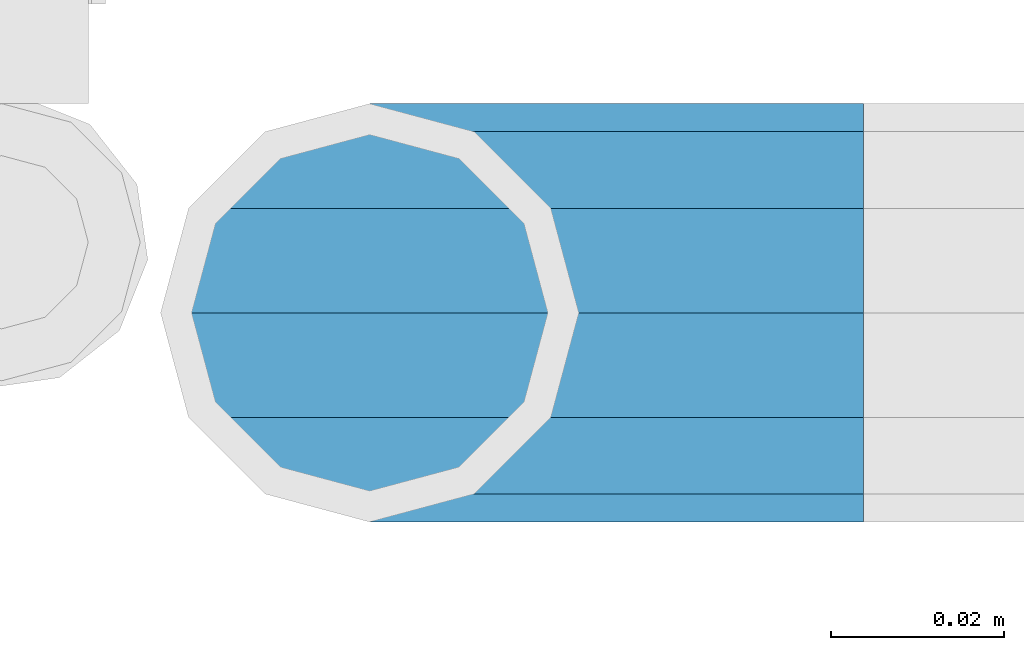
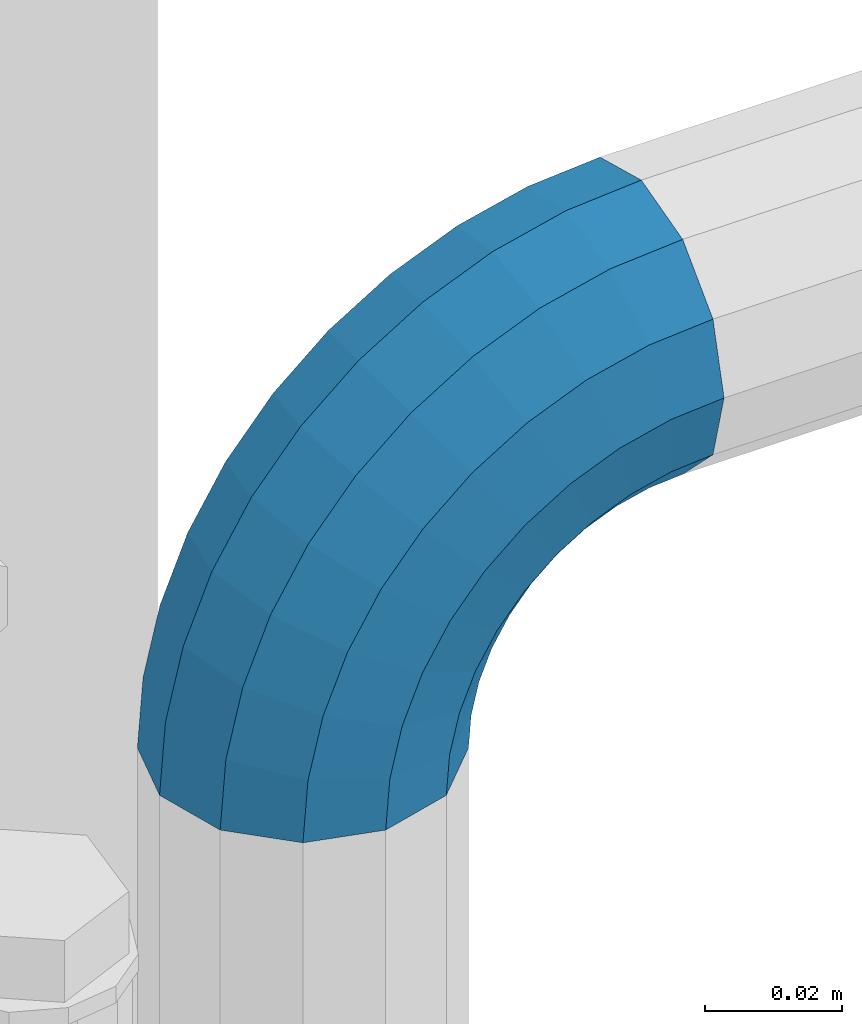
# One storey, part 146 of 208: 1 member.
"""IFC2X3 building model written with IfcOpenShell, lengths in millimetres."""

import ifcopenshell
import ifcopenshell.guid

model = None  # the IFC model being written
_history = None  # IfcOwnerHistory: only IFC2X3 demands one
_inside = {}  # id of a spatial element -> (the spatial element, [elements in it])
_under = {}  # id of a project, library or spatial element -> (it, [spatial elements below it])
_declared = {}  # id of a project -> (the project, [libraries it declares])
_typed = {}  # id of a type object -> (the type object, [elements of that type])
_made_of = {}  # id of a material, layer set ... -> (it, [elements and type objects made of it])


def new_model(schema):
    """Start an empty IFC model of exactly this schema.

    Asked for "IFC4X3", IfcOpenShell would pick the latest addendum, in which some entities
    have other attributes; the version numbers below select the first issue.
    IFC2X3 requires an IfcOwnerHistory on every rooted entity: one is made here for all.
    """
    global model, _history
    if schema == "IFC4X3":
        model = ifcopenshell.file(schema_version=(4, 3, 0, 0))
    else:
        model = ifcopenshell.file(schema=schema)
    _inside.clear()
    _under.clear()
    _declared.clear()
    _typed.clear()
    _made_of.clear()
    _history = None
    if model.schema == "IFC2X3":
        org = make("IfcOrganization", Name="unknown")
        user = make(
            "IfcPersonAndOrganization",
            ThePerson=make("IfcPerson", FamilyName="unknown"),
            TheOrganization=org,
        )
        app = make(
            "IfcApplication",
            ApplicationDeveloper=org,
            Version="unknown",
            ApplicationFullName="unknown",
            ApplicationIdentifier="unknown",
        )
        _history = make(
            "IfcOwnerHistory",
            OwningUser=user,
            OwningApplication=app,
            ChangeAction="ADDED",
            CreationDate=0,
        )
    return model


def make(cls, **values):
    """One entity of the class cls with the attributes given. An attribute that is None is left unset."""
    return model.create_entity(
        cls, **{name: value for name, value in values.items() if value is not None}
    )


def rooted(cls, **values):
    """An entity with a GlobalId (a new one), such as an element, a storey or a relation."""
    return make(cls, GlobalId=ifcopenshell.guid.new(), OwnerHistory=_history, **values)


def si_unit(unit_type, name, prefix=None):
    """IfcSIUnit, for example si_unit("LENGTHUNIT", "METRE", prefix="MILLI")."""
    return make("IfcSIUnit", UnitType=unit_type, Prefix=prefix, Name=name)


def assignment(units):
    """IfcUnitAssignment: the units of a project."""
    return None if units is None else make("IfcUnitAssignment", Units=units)


def point(xyz):
    """IfcCartesianPoint."""
    return None if xyz is None else make("IfcCartesianPoint", Coordinates=xyz)


def direction(xyz):
    """IfcDirection."""
    return None if xyz is None else make("IfcDirection", DirectionRatios=xyz)


def frame(location, z_axis=None, x_axis=None):
    """IfcAxis2Placement3D, a coordinate frame: its origin and axes. An axis left out is left unset."""
    return make(
        "IfcAxis2Placement3D",
        Location=point(location),
        Axis=direction(z_axis),
        RefDirection=direction(x_axis),
    )


def origin_with_axes():
    """The frame at (0, 0, 0) with the z axis (0, 0, 1) and the x axis (1, 0, 0) written out."""
    return frame((0.0, 0.0, 0.0), z_axis=(0.0, 0.0, 1.0), x_axis=(1.0, 0.0, 0.0))


def place(relative_to, where):
    """IfcLocalPlacement: puts the frame where relative to a parent placement (None: the world)."""
    return make(
        "IfcLocalPlacement", PlacementRelTo=relative_to, RelativePlacement=where
    )


def context(
    kind, dimensions, precision=None, world=None, true_north=None, identifier=None
):
    """IfcGeometricRepresentationContext, for example the 3D "Model" context."""
    return make(
        "IfcGeometricRepresentationContext",
        ContextIdentifier=identifier,
        ContextType=kind,
        CoordinateSpaceDimension=dimensions,
        Precision=precision,
        WorldCoordinateSystem=world,
        TrueNorth=true_north,
    )


def subcontext(parent, identifier, kind, view, scale=None):
    """IfcGeometricRepresentationSubContext, for example "Body" below "Model"."""
    return make(
        "IfcGeometricRepresentationSubContext",
        ContextIdentifier=identifier,
        ContextType=kind,
        ParentContext=parent,
        TargetScale=scale,
        TargetView=view,
    )


def project(units=None, contexts=None):
    """IfcProject with its units and contexts."""
    return rooted(
        "IfcProject",
        Name="project",
        RepresentationContexts=contexts,
        UnitsInContext=assignment(units),
    )


def spatial(cls, under=None, at=None, **own):
    """A site, building, storey or space (cls), placed at a placement, below another one or the project."""
    s = rooted(cls, ObjectPlacement=at, **own)
    if under is not None:
        _under.setdefault(under.id(), (under, []))[1].append(s)
    return s


def faces_of(points, faces, orient=None, outer=None):
    """IfcFace entities. A face is a list of loops; a loop is a list of indices into points, from 0.

    orient and outer hold one flag for each loop. By default every Orientation is true, the
    first loop of a face is its IfcFaceOuterBound and the others are IfcFaceBound.
    """
    made = []
    for i, loops in enumerate(faces):
        bounds = []
        for j, loop in enumerate(loops):
            is_outer = j == 0 if outer is None else outer[i][j]
            bounds.append(
                make(
                    "IfcFaceOuterBound" if is_outer else "IfcFaceBound",
                    Bound=make("IfcPolyLoop", Polygon=[points[k] for k in loop]),
                    Orientation=True if orient is None else orient[i][j],
                )
            )
        made.append(make("IfcFace", Bounds=bounds))
    return made


def faceted_brep(points, faces, orient=None, outer=None, voids=None):
    """IfcFacetedBrep: a solid bounded by flat faces; with voids (closed shells), ...WithVoids."""
    shared = [point(p) for p in points]
    hull = make("IfcClosedShell", CfsFaces=faces_of(shared, faces, orient, outer))
    if voids is None:
        return make("IfcFacetedBrep", Outer=hull)
    return make(
        "IfcFacetedBrepWithVoids",
        Outer=hull,
        Voids=[
            make(cls, CfsFaces=faces_of(shared, fs, o, b)) for cls, fs, o, b in voids
        ],
    )


def shape(context_of_items, identifier, shape_type, items):
    """IfcShapeRepresentation: the items that make up one representation, for example the "Body"."""
    return make(
        "IfcShapeRepresentation",
        ContextOfItems=context_of_items,
        RepresentationIdentifier=identifier,
        RepresentationType=shape_type,
        Items=items,
    )


def material(Name=None, Category=None):
    """IfcMaterial."""
    return make("IfcMaterial", Name=Name, Category=Category)


def made_of(thing, what):
    """Note that an element or type object is made of a material, layer set ...; save() writes the relation."""
    if what is not None:
        _made_of.setdefault(what.id(), (what, []))[1].append(thing)
    return thing


def type_object(cls, material=None, **own):
    """A type object (cls), such as IfcWallType, which elements share."""
    return made_of(rooted(cls, **own), material)


def element(
    cls,
    number,
    at=None,
    inside=None,
    cuts=None,
    type_object=None,
    material=None,
    context=None,
    identifier="Body",
    shape_type=None,
    held_by="IfcProductDefinitionShape",
    body=None,
    shapes=None,
    **own,
):
    """One element of the class cls, such as IfcWall. Its Tag is "e" and its number.

    at: its placement. inside: the storey or other place that contains it. cuts: it is an
    opening in that element (IfcRelVoidsElement). A single representation is given by context,
    identifier, shape_type and body (its items); several are given by shapes. held_by: the class
    of the entity that holds the representations. save() writes the other relations.
    """
    e = rooted(cls, Tag="e%d" % number, ObjectPlacement=at, **own)
    if body is not None:
        shapes = [shape(context, identifier, shape_type, body)]
    if shapes is not None:
        e.Representation = make(held_by, Representations=shapes)
    if inside is not None:
        _inside.setdefault(inside.id(), (inside, []))[1].append(e)
    if cuts is not None:
        rooted(
            "IfcRelVoidsElement", RelatingBuildingElement=cuts, RelatedOpeningElement=e
        )
    if type_object is not None:
        _typed.setdefault(type_object.id(), (type_object, []))[1].append(e)
    return made_of(e, material)


def aggregate(whole, parts):
    """IfcRelAggregates: a whole, such as a stair, and the parts it consists of."""
    return rooted("IfcRelAggregates", RelatingObject=whole, RelatedObjects=parts)


def save(model, path):
    """Write the relations noted so far, then the file.

    IfcRelAggregates (storeys below a building ...), IfcRelContainedInSpatialStructure (elements
    in a storey), IfcRelDefinesByType, IfcRelAssociatesMaterial and IfcRelDeclares: one each for
    every whole, place, type object, material and project.
    """
    for whole, parts in _under.values():
        aggregate(whole, parts)
    for where, things in _inside.values():
        rooted(
            "IfcRelContainedInSpatialStructure",
            RelatedElements=things,
            RelatingStructure=where,
        )
    for kind, things in _typed.values():
        rooted("IfcRelDefinesByType", RelatedObjects=things, RelatingType=kind)
    for what, things in _made_of.values():
        rooted("IfcRelAssociatesMaterial", RelatedObjects=things, RelatingMaterial=what)
    for by, libraries in _declared.values():
        rooted("IfcRelDeclares", RelatingContext=by, RelatedDefinitions=libraries)
    model.write(path)


model = new_model("IFC2X3")

# Units and contexts
model_context = context("Model", 3, precision=1e-05, world=origin_with_axes())
body_context = subcontext(model_context, "Body", "Model", "MODEL_VIEW")
ifc_project = project(units=[si_unit("LENGTHUNIT", "METRE", prefix="MILLI"), si_unit("AREAUNIT", "SQUARE_METRE"), si_unit("VOLUMEUNIT", "CUBIC_METRE"), si_unit("MASSUNIT", "GRAM", prefix="KILO"), si_unit("TIMEUNIT", "SECOND"), si_unit("PLANEANGLEUNIT", "RADIAN"), si_unit("SOLIDANGLEUNIT", "STERADIAN"), si_unit("THERMODYNAMICTEMPERATUREUNIT", "DEGREE_CELSIUS"), si_unit("LUMINOUSINTENSITYUNIT", "LUMEN")], contexts=[model_context])

# Site, building, storey
site_placement = place(None, origin_with_axes())
site = spatial("IfcSite", under=ifc_project, at=site_placement, CompositionType="ELEMENT")
building_placement = place(site_placement, origin_with_axes())
building = spatial("IfcBuilding", under=site, at=building_placement, Name="Standard", CompositionType="ELEMENT")
storey_placement = place(building_placement, origin_with_axes())
storey = spatial("IfcBuildingStorey", under=building, at=storey_placement, Name="Undefined", CompositionType="ELEMENT", Elevation=0.0)

# Member
ifc_material = material()
member_type = type_object("IfcMemberType", PredefinedType="NOTDEFINED")
member_placement = place(storey_placement, frame((-15494.7539827644, 2941.85399999618, 935.350006544462), z_axis=(0.0, 1.0, 0.0), x_axis=(-0.707106781186548, 0.0, -0.707106781186548)))
element("IfcMember", 1, at=member_placement, inside=storey, type_object=member_type, material=ifc_material, context=body_context, shape_type="Brep", body=[
    faceted_brep([(17.0766287656552, -17.0766287656552, 0.0), (14.7887943220539, -14.7887943220539, -12.0749999999998), (19.0945697419538, -11.1113146999724, -12.0749999999998), (20.9963409898282, -13.7288782624146, 0.0), (8.53831438282759, -8.53831438282759, -20.9145135013941), (13.8988340683954, -3.95999805533756, -20.9145135013941), (0.0, 0.0, -24.1500000000001), (6.80132714696265, 5.80888215173945, -24.1500000000001), (-8.53831438282759, 8.53831438282759, -20.9145135013941), (-0.296179774470147, 15.5777623588165, -20.9145135013941), (-14.7887943220521, 14.7887943220521, -12.0749999999998), (-5.49191544802852, 22.7290790034513, -12.0749999999998), (-17.0766287656552, 17.0766287656552, 0.0), (-7.39368669589931, 25.3466425658935, 0.0), (-14.7887943220521, 14.7887943220521, 12.0749999999998), (-5.49191544802852, 22.7290790034513, 12.0749999999998), (-8.53831438282759, 8.53831438282759, 20.9145135013941), (-0.296179774470147, 15.5777623588165, 20.9145135013941), (0.0, 0.0, 24.1500000000001), (6.80132714696265, 5.80888215173945, 24.1500000000001), (8.53831438282759, -8.53831438282759, 20.9145135013941), (13.8988340683954, -3.95999805533756, 20.9145135013941), (14.7887943220539, -14.7887943220539, 12.0749999999998), (19.0945697419538, -11.1113146999724, 12.0749999999998), (14.5310443533836, -14.5310443533836, 0.0), (12.5842535535485, -12.5842535535485, 10.2750000000001), (17.2620366843166, -8.58904933077247, 10.2750000000001), (18.8803140815726, -10.8164170826676, 0.0), (7.26552217669268, -7.26552217669268, 17.7968220477701), (12.8408206142685, -2.50376746546499, 17.7968220477701), (0.0, 0.0, 20.5500000000002), (6.80132714696265, 5.80888215173945, 20.5500000000002), (-7.26552217669087, 7.26552217669087, 17.7968220477701), (0.761833679658594, 14.1215317689421, 17.7968220477701), (-12.5842535535485, 12.5842535535485, 10.2750000000001), (-3.65938239039133, 20.2068136342514, 10.2750000000001), (-14.5310443533836, 14.5310443533836, 0.0), (-5.27765978764546, 22.4341813861447, 0.0), (-12.5842535535485, 12.5842535535485, -10.2750000000001), (-3.65938239039133, 20.2068136342514, -10.2750000000001), (-7.26552217669087, 7.26552217669087, -17.7968220477701), (0.761833679658594, 14.1215317689421, -17.7968220477701), (0.0, 0.0, -20.5500000000002), (6.80132714696265, 5.80888215173945, -20.5500000000002), (7.26552217669268, -7.26552217669268, -17.7968220477701), (12.8408206142685, -2.50376746546499, -17.7968220477701), (12.5842535535485, -12.5842535535485, -10.2750000000001), (17.2620366843166, -8.58904933077247, -10.2750000000001), (23.9226184787876, -8.15268262886457, -12.0749999999998), (25.3914986111904, -11.0355222080452, 0.0), (19.9095633268353, -0.27661842847192, -20.9145135013941), (14.4276280424801, 10.482285351105, -24.1500000000001), (8.94569275812501, 21.2411891306783, -20.9145135013941), (4.93263760617265, 29.117253331071, -12.0749999999998), (3.46375747377169, 32.0000929102534, 0.0), (4.93263760617265, 29.117253331071, 12.0749999999998), (8.94569275812501, 21.2411891306783, 20.9145135013941), (14.4276280424801, 10.482285351105, 24.1500000000001), (19.9095633268353, -0.27661842847192, 20.9145135013941), (23.9226184787876, -8.15268262886457, 12.0749999999998), (22.5072161777225, -5.3747992032786, 10.2750000000001), (23.7571328121267, -7.82789872096691, 0.0), (19.0923804273043, 1.32719331506814, 17.7968220477701), (14.4276280424801, 10.482285351105, 20.5500000000002), (9.76287565765597, 19.6373773871383, 17.7968220477701), (6.34803990723776, 26.3393699054886, 10.2750000000001), (5.0981232728318, 28.7924694231751, 0.0), (6.34803990723776, 26.3393699054886, -10.2750000000001), (9.76287565765597, 19.6373773871383, -17.7968220477701), (14.4276280424801, 10.482285351105, -20.5500000000002), (19.0923804273043, 1.32719331506814, -17.7968220477701), (22.5072161777225, -5.3747992032786, -10.2750000000001), (29.1540579492776, -5.98574944945176, -12.0749999999998), (30.1538782624175, -9.06287996733772, 0.0), (26.422498055339, 2.42112746692692, -20.9145135013941), (22.6911178482624, 13.9051349011897, -24.1500000000001), (18.9597376411857, 25.3891423354562, -20.9145135013941), (16.2281777472472, 33.7960192518349, -12.0749999999998), (15.2283574341091, 36.873149769719, 0.0), (16.2281777472472, 33.7960192518349, 12.0749999999998), (18.9597376411857, 25.3891423354562, 20.9145135013941), (22.6911178482624, 13.9051349011897, 24.1500000000001), (26.422498055339, 2.42112746692692, 20.9145135013941), (29.1540579492776, -5.98574944945176, 12.0749999999998), (28.1906383068908, -3.0206486766856, 10.2750000000001), (29.041417082668, -5.63907650867441, 0.0), (25.8662674654661, 4.13302919625858, 17.7968220477701), (22.6911178482624, 13.9051349011897, 20.5500000000002), (19.5159682310605, 23.6772406061227, 17.7968220477701), (17.1915973896339, 30.8309184790687, 10.2750000000001), (16.3408186138568, 33.4493463110575, 0.0), (17.1915973896339, 30.8309184790687, -10.2750000000001), (19.5159682310605, 23.6772406061227, -17.7968220477701), (22.6911178482624, 13.9051349011897, -20.5500000000002), (25.8662674654661, 4.13302919625858, -17.7968220477701), (28.1906383068908, -3.0206486766856, -10.2750000000001), (34.660072751507, -4.66387224825667, -12.0749999999998), (35.1662143510621, -7.85952453908249, 0.0), (33.2772681857005, 4.06681217360347, -20.9145135013941), (31.3883220203406, 15.9931488862876, -24.1500000000001), (29.4993758549808, 27.9194855989754, -20.9145135013941), (28.1165712891743, 36.6501700208355, -12.0749999999998), (27.6104296896192, 39.8458223116613, 0.0), (28.1165712891743, 36.6501700208355, 12.0749999999998), (29.4993758549808, 27.9194855989754, 20.9145135013941), (31.3883220203406, 15.9931488862876, 24.1500000000001), (33.2772681857005, 4.06681217360347, 20.9145135013941), (34.660072751507, -4.66387224825667, 12.0749999999998), (34.1723583568, -1.58456474993909, 10.2750000000001), (34.6030502769172, -4.30384651293934, 0.0), (32.995686148628, 5.84465118667504, 17.7968220477701), (31.3883220203406, 15.9931488862876, 20.5500000000002), (29.7809578920533, 26.1416465859038, 17.7968220477701), (28.6042856838831, 33.5708625225197, 10.2750000000001), (28.1735937637659, 36.29014428552, 0.0), (28.6042856838831, 33.5708625225197, -10.2750000000001), (29.7809578920533, 26.1416465859038, -17.7968220477701), (31.3883220203406, 15.9931488862876, -20.5500000000002), (32.995686148628, 5.84465118667504, -17.7968220477701), (34.1723583568, -1.58456474993909, -10.2750000000001), (40.3050865276346, -4.21960002902779, -12.0749999999998), (40.3050865276346, -7.45508652763237, 0.0), (40.3050865276327, 4.61991347236653, -20.9145135013941), (40.3050865276327, 16.6949134723673, -24.1500000000001), (40.3050865276346, 28.7699134723662, -20.9145135013941), (40.3050865276346, 37.6094269737623, -12.0749999999998), (40.3050865276346, 40.8449134723669, 0.0), (40.3050865276346, 37.6094269737623, 12.0749999999998), (40.3050865276346, 28.7699134723662, 20.9145135013941), (40.3050865276327, 16.6949134723673, 24.1500000000001), (40.3050865276327, 4.61991347236653, 20.9145135013941), (40.3050865276346, -4.21960002902779, 12.0749999999998), (40.3050865276327, -1.10190857540329, 10.2750000000001), (40.3050865276346, -3.85508652763383, 0.0), (40.3050865276346, 6.41991347236763, 17.7968220477701), (40.3050865276327, 16.6949134723673, 20.5500000000002), (40.3050865276346, 26.9699134723669, 17.7968220477701), (40.3050865276346, 34.491735520136, 10.2750000000001), (40.3050865276327, 37.2449134723665, 0.0), (40.3050865276346, 34.491735520136, -10.2750000000001), (40.3050865276346, 26.9699134723669, -17.7968220477701), (40.3050865276327, 16.6949134723673, -20.5500000000002), (40.3050865276346, 6.41991347236763, -17.7968220477701), (40.3050865276327, -1.10190857540329, -10.2750000000001), (45.9501003037603, -4.66387224825485, -12.0749999999998), (45.4439587042052, -7.8595245390843, 0.0), (47.3329048695668, 4.06681217360529, -20.9145135013941), (49.2218510349267, 15.9931488862894, -24.1500000000001), (51.1107972002883, 27.9194855989754, -20.9145135013941), (52.4936017660948, 36.6501700208355, -12.0749999999998), (52.9997433656481, 39.8458223116631, 0.0), (52.4936017660948, 36.6501700208355, 12.0749999999998), (51.1107972002883, 27.9194855989754, 20.9145135013941), (49.2218510349267, 15.9931488862894, 24.1500000000001), (47.3329048695668, 4.06681217360529, 20.9145135013941), (45.9501003037603, -4.66387224825485, 12.0749999999998), (46.4378146984691, -1.58456474993909, 10.2750000000001), (46.0071227783501, -4.30384651294116, 0.0), (47.6144869066393, 5.84465118667322, 17.7968220477701), (49.2218510349267, 15.9931488862894, 20.5500000000002), (50.8292151632158, 26.1416465859038, 17.7968220477701), (52.0058873713861, 33.5708625225197, 10.2750000000001), (52.4365792915032, 36.29014428552, 0.0), (52.0058873713861, 33.5708625225197, -10.2750000000001), (50.8292151632158, 26.1416465859038, -17.7968220477701), (49.2218510349267, 15.9931488862894, -20.5500000000002), (47.6144869066393, 5.84465118667322, -17.7968220477701), (46.4378146984691, -1.58456474993909, -10.2750000000001), (51.4561151059897, -5.98574944945358, -12.0749999999998), (50.4562947928516, -9.06287996733772, 0.0), (54.1876749999301, 2.42112746692692, -20.9145135013941), (57.9190552070068, 13.9051349011897, -24.1500000000001), (61.6504354140834, 25.3891423354562, -20.9145135013941), (64.3819953080219, 33.7960192518349, -12.0749999999998), (65.3818156211601, 36.873149769719, 0.0), (64.3819953080219, 33.7960192518349, 12.0749999999998), (61.6504354140834, 25.3891423354562, 20.9145135013941), (57.9190552070068, 13.9051349011897, 24.1500000000001), (54.1876749999301, 2.42112746692692, 20.9145135013941), (51.4561151059897, -5.98574944945358, 12.0749999999998), (52.4195347483783, -3.0206486766856, 10.2750000000001), (51.5687559726011, -5.63907650867441, 0.0), (54.743905589803, 4.13302919625858, 17.7968220477701), (57.9190552070068, 13.9051349011897, 20.5500000000002), (61.0942048242086, 23.6772406061227, 17.7968220477701), (63.4185756656334, 30.8309184790669, 10.2750000000001), (64.2693544414105, 33.4493463110557, 0.0), (63.4185756656334, 30.8309184790669, -10.2750000000001), (61.0942048242086, 23.6772406061227, -17.7968220477701), (57.9190552070068, 13.9051349011897, -20.5500000000002), (54.743905589803, 4.13302919625858, -17.7968220477701), (52.4195347483783, -3.0206486766856, -10.2750000000001), (56.6875545764815, -8.15268262886457, -12.0749999999998), (55.2186744440787, -11.0355222080452, 0.0), (60.7006097284338, -0.27661842847192, -20.9145135013941), (66.182545012789, 10.482285351105, -24.1500000000001), (71.6644802971441, 21.2411891306783, -20.9145135013941), (75.6775354490965, 29.117253331071, -12.0749999999998), (77.1464155814974, 32.0000929102534, 0.0), (75.6775354490965, 29.117253331071, 12.0749999999998), (71.6644802971441, 21.2411891306783, 20.9145135013941), (66.182545012789, 10.482285351105, 24.1500000000001), (60.7006097284338, -0.27661842847192, 20.9145135013941), (56.6875545764815, -8.15268262886457, 12.0749999999998), (58.1029568775466, -5.3747992032786, 10.2750000000001), (56.8530402431425, -7.82789872096691, 0.0), (61.5177926279648, 1.32719331506814, 17.7968220477701), (66.182545012789, 10.482285351105, 20.5500000000002), (70.8472973976113, 19.6373773871401, 17.7968220477701), (74.2621331480332, 26.3393699054868, 10.2750000000001), (75.5120497824355, 28.7924694231733, 0.0), (74.2621331480332, 26.3393699054868, -10.2750000000001), (70.8472973976113, 19.6373773871401, -17.7968220477701), (66.182545012789, 10.482285351105, -20.5500000000002), (61.5177926279648, 1.32719331506814, -17.7968220477701), (58.1029568775466, -5.3747992032786, -10.2750000000001), (61.5156033133135, -11.1113146999742, -12.0749999999998), (59.6138320654427, -13.7288782624164, 0.0), (66.7113389868737, -3.95999805533756, -20.9145135013941), (73.8088459083046, 5.80888215173763, -24.1500000000001), (80.9063528297374, 15.5777623588183, -20.9145135013941), (86.1020885032976, 22.7290790034513, -12.0749999999998), (88.0038597511684, 25.3466425658935, 0.0), (86.1020885032976, 22.7290790034513, 12.0749999999998), (80.9063528297374, 15.5777623588183, 20.9145135013941), (73.8088459083046, 5.80888215173763, 24.1500000000001), (66.7113389868737, -3.95999805533756, 20.9145135013941), (61.5156033133135, -11.1113146999742, 12.0749999999998), (63.3481363709525, -8.58904933077247, 10.2750000000001), (61.7298589736947, -10.8164170826658, 0.0), (67.7693524409988, -2.50376746546317, 17.7968220477701), (73.8088459083046, 5.80888215173763, 20.5500000000002), (79.8483393756105, 14.1215317689421, 17.7968220477701), (84.2695554456586, 20.2068136342532, 10.2750000000001), (85.8878328429146, 22.4341813861447, 0.0), (84.2695554456586, 20.2068136342532, -10.2750000000001), (79.8483393756105, 14.1215317689421, -17.7968220477701), (73.8088459083046, 5.80888215173763, -20.5500000000002), (67.7693524409988, -2.50376746546317, -17.7968220477701), (63.3481363709525, -8.58904933077247, -10.2750000000001), (65.8213787332152, -14.7887943220539, -12.0749999999998), (63.5335442896121, -17.0766287656534, 0.0), (72.0718586724379, -8.53831438282759, -20.9145135013941), (80.6101730552673, 1.81898940354586e-12, -24.1500000000001), (89.1484874380967, 8.53831438282759, -20.9145135013941), (95.3989673773231, 14.7887943220539, -12.0749999999998), (97.6868018209225, 17.0766287656534, 0.0), (95.3989673773231, 14.7887943220539, 12.0749999999998), (89.1484874380967, 8.53831438282759, 20.9145135013941), (80.6101730552673, 1.81898940354586e-12, 24.1500000000001), (72.0718586724379, -8.53831438282759, 20.9145135013941), (65.8213787332152, -14.7887943220539, 12.0749999999998), (68.0259195017188, -12.5842535535503, 10.2750000000001), (66.0791287018856, -14.5310443533836, 0.0), (73.3446508785764, -7.26552217669268, 17.7968220477701), (80.6101730552673, 1.81898940354586e-12, 20.5500000000002), (87.8756952319582, 7.26552217669268, 17.7968220477701), (93.1944266088158, 12.5842535535503, 10.2750000000001), (95.141217408649, 14.5310443533836, 0.0), (93.1944266088158, 12.5842535535503, -10.2750000000001), (87.8756952319582, 7.26552217669268, -17.7968220477701), (80.6101730552673, 1.81898940354586e-12, -20.5500000000002), (73.3446508785764, -7.26552217669268, -17.7968220477701), (68.0259195017188, -12.5842535535503, -10.2750000000001)], [[[0, 1, 2, 3]], [[1, 4, 5, 2]], [[4, 6, 7, 5]], [[6, 8, 9, 7]], [[8, 10, 11, 9]], [[10, 12, 13, 11]], [[12, 14, 15, 13]], [[14, 16, 17, 15]], [[16, 18, 19, 17]], [[18, 20, 21, 19]], [[20, 22, 23, 21]], [[22, 0, 3, 23]], [[24, 25, 26, 27]], [[25, 28, 29, 26]], [[28, 30, 31, 29]], [[30, 32, 33, 31]], [[32, 34, 35, 33]], [[34, 36, 37, 35]], [[36, 38, 39, 37]], [[38, 40, 41, 39]], [[40, 42, 43, 41]], [[42, 44, 45, 43]], [[44, 46, 47, 45]], [[46, 24, 27, 47]], [[22, 20, 18, 16, 14, 12, 10, 8, 6, 4, 1, 0], [46, 44, 42, 40, 38, 36, 34, 32, 30, 28, 25, 24]], [[3, 2, 48, 49]], [[2, 5, 50, 48]], [[5, 7, 51, 50]], [[7, 9, 52, 51]], [[9, 11, 53, 52]], [[11, 13, 54, 53]], [[13, 15, 55, 54]], [[15, 17, 56, 55]], [[17, 19, 57, 56]], [[19, 21, 58, 57]], [[21, 23, 59, 58]], [[23, 3, 49, 59]], [[27, 26, 60, 61]], [[26, 29, 62, 60]], [[29, 31, 63, 62]], [[31, 33, 64, 63]], [[33, 35, 65, 64]], [[35, 37, 66, 65]], [[37, 39, 67, 66]], [[39, 41, 68, 67]], [[41, 43, 69, 68]], [[43, 45, 70, 69]], [[45, 47, 71, 70]], [[47, 27, 61, 71]], [[49, 48, 72, 73]], [[48, 50, 74, 72]], [[50, 51, 75, 74]], [[51, 52, 76, 75]], [[52, 53, 77, 76]], [[53, 54, 78, 77]], [[54, 55, 79, 78]], [[55, 56, 80, 79]], [[56, 57, 81, 80]], [[57, 58, 82, 81]], [[58, 59, 83, 82]], [[59, 49, 73, 83]], [[61, 60, 84, 85]], [[60, 62, 86, 84]], [[62, 63, 87, 86]], [[63, 64, 88, 87]], [[64, 65, 89, 88]], [[65, 66, 90, 89]], [[66, 67, 91, 90]], [[67, 68, 92, 91]], [[68, 69, 93, 92]], [[69, 70, 94, 93]], [[70, 71, 95, 94]], [[71, 61, 85, 95]], [[73, 72, 96, 97]], [[72, 74, 98, 96]], [[74, 75, 99, 98]], [[75, 76, 100, 99]], [[76, 77, 101, 100]], [[77, 78, 102, 101]], [[78, 79, 103, 102]], [[79, 80, 104, 103]], [[80, 81, 105, 104]], [[81, 82, 106, 105]], [[82, 83, 107, 106]], [[83, 73, 97, 107]], [[85, 84, 108, 109]], [[84, 86, 110, 108]], [[86, 87, 111, 110]], [[87, 88, 112, 111]], [[88, 89, 113, 112]], [[89, 90, 114, 113]], [[90, 91, 115, 114]], [[91, 92, 116, 115]], [[92, 93, 117, 116]], [[93, 94, 118, 117]], [[94, 95, 119, 118]], [[95, 85, 109, 119]], [[97, 96, 120, 121]], [[96, 98, 122, 120]], [[98, 99, 123, 122]], [[99, 100, 124, 123]], [[100, 101, 125, 124]], [[101, 102, 126, 125]], [[102, 103, 127, 126]], [[103, 104, 128, 127]], [[104, 105, 129, 128]], [[105, 106, 130, 129]], [[106, 107, 131, 130]], [[107, 97, 121, 131]], [[109, 108, 132, 133]], [[108, 110, 134, 132]], [[110, 111, 135, 134]], [[111, 112, 136, 135]], [[112, 113, 137, 136]], [[113, 114, 138, 137]], [[114, 115, 139, 138]], [[115, 116, 140, 139]], [[116, 117, 141, 140]], [[117, 118, 142, 141]], [[118, 119, 143, 142]], [[119, 109, 133, 143]], [[121, 120, 144, 145]], [[120, 122, 146, 144]], [[122, 123, 147, 146]], [[123, 124, 148, 147]], [[124, 125, 149, 148]], [[125, 126, 150, 149]], [[126, 127, 151, 150]], [[127, 128, 152, 151]], [[128, 129, 153, 152]], [[129, 130, 154, 153]], [[130, 131, 155, 154]], [[131, 121, 145, 155]], [[133, 132, 156, 157]], [[132, 134, 158, 156]], [[134, 135, 159, 158]], [[135, 136, 160, 159]], [[136, 137, 161, 160]], [[137, 138, 162, 161]], [[138, 139, 163, 162]], [[139, 140, 164, 163]], [[140, 141, 165, 164]], [[141, 142, 166, 165]], [[142, 143, 167, 166]], [[143, 133, 157, 167]], [[145, 144, 168, 169]], [[144, 146, 170, 168]], [[146, 147, 171, 170]], [[147, 148, 172, 171]], [[148, 149, 173, 172]], [[149, 150, 174, 173]], [[150, 151, 175, 174]], [[151, 152, 176, 175]], [[152, 153, 177, 176]], [[153, 154, 178, 177]], [[154, 155, 179, 178]], [[155, 145, 169, 179]], [[157, 156, 180, 181]], [[156, 158, 182, 180]], [[158, 159, 183, 182]], [[159, 160, 184, 183]], [[160, 161, 185, 184]], [[161, 162, 186, 185]], [[162, 163, 187, 186]], [[163, 164, 188, 187]], [[164, 165, 189, 188]], [[165, 166, 190, 189]], [[166, 167, 191, 190]], [[167, 157, 181, 191]], [[169, 168, 192, 193]], [[168, 170, 194, 192]], [[170, 171, 195, 194]], [[171, 172, 196, 195]], [[172, 173, 197, 196]], [[173, 174, 198, 197]], [[174, 175, 199, 198]], [[175, 176, 200, 199]], [[176, 177, 201, 200]], [[177, 178, 202, 201]], [[178, 179, 203, 202]], [[179, 169, 193, 203]], [[181, 180, 204, 205]], [[180, 182, 206, 204]], [[182, 183, 207, 206]], [[183, 184, 208, 207]], [[184, 185, 209, 208]], [[185, 186, 210, 209]], [[186, 187, 211, 210]], [[187, 188, 212, 211]], [[188, 189, 213, 212]], [[189, 190, 214, 213]], [[190, 191, 215, 214]], [[191, 181, 205, 215]], [[193, 192, 216, 217]], [[192, 194, 218, 216]], [[194, 195, 219, 218]], [[195, 196, 220, 219]], [[196, 197, 221, 220]], [[197, 198, 222, 221]], [[198, 199, 223, 222]], [[199, 200, 224, 223]], [[200, 201, 225, 224]], [[201, 202, 226, 225]], [[202, 203, 227, 226]], [[203, 193, 217, 227]], [[205, 204, 228, 229]], [[204, 206, 230, 228]], [[206, 207, 231, 230]], [[207, 208, 232, 231]], [[208, 209, 233, 232]], [[209, 210, 234, 233]], [[210, 211, 235, 234]], [[211, 212, 236, 235]], [[212, 213, 237, 236]], [[213, 214, 238, 237]], [[214, 215, 239, 238]], [[215, 205, 229, 239]], [[217, 216, 240, 241]], [[216, 218, 242, 240]], [[218, 219, 243, 242]], [[219, 220, 244, 243]], [[220, 221, 245, 244]], [[221, 222, 246, 245]], [[222, 223, 247, 246]], [[223, 224, 248, 247]], [[224, 225, 249, 248]], [[225, 226, 250, 249]], [[226, 227, 251, 250]], [[227, 217, 241, 251]], [[229, 228, 252, 253]], [[228, 230, 254, 252]], [[230, 231, 255, 254]], [[231, 232, 256, 255]], [[232, 233, 257, 256]], [[233, 234, 258, 257]], [[234, 235, 259, 258]], [[235, 236, 260, 259]], [[236, 237, 261, 260]], [[237, 238, 262, 261]], [[238, 239, 263, 262]], [[239, 229, 253, 263]], [[242, 243, 244, 245, 246, 247, 248, 249, 250, 251, 241, 240], [254, 255, 256, 257, 258, 259, 260, 261, 262, 263, 253, 252]]]),
])

save(model, "model.ifc")
